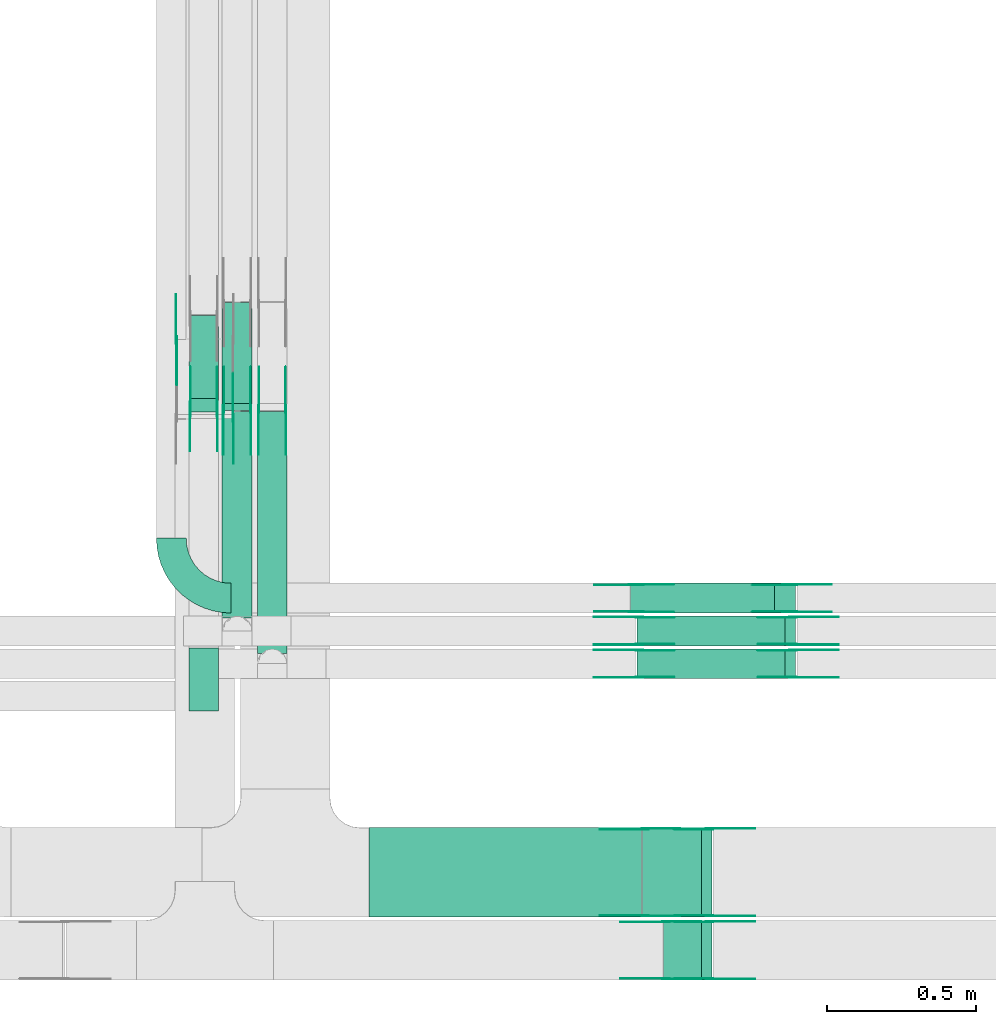
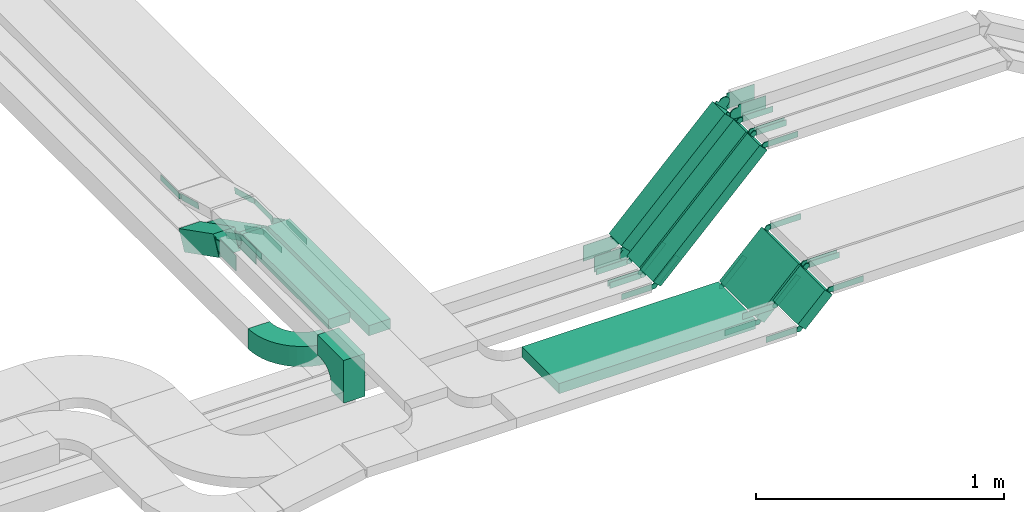
# One storey, part 15 of 19: 58 flow fittings, 10 flow segments.
"""IFC2X3 building model written with IfcOpenShell, lengths in millimetres."""

from ifc_helpers import new_model, entity, si_unit, converted_unit, derived_unit, direction, frame, frame_2d, origin, origin_2d_with_axis, place, context, subcontext, project, spatial, polyline, circle_curve, parameter, trimmed, segment, composite_curve, rectangle, outline, extrude, source, transform, mapped, material, type_object, type_shapes, element, save


model = new_model("IFC2X3")

# Units and contexts
model_context = context("Model", 3, precision=0.01, world=origin(), true_north=direction((6.12303176911189e-17, 1.0)))
body_context = subcontext(model_context, "Body", "Model", "MODEL_VIEW")
ifc_project = project(units=[si_unit("LENGTHUNIT", "METRE", prefix="MILLI"), si_unit("AREAUNIT", "SQUARE_METRE"), si_unit("VOLUMEUNIT", "CUBIC_METRE"), converted_unit("PLANEANGLEUNIT", "DEGREE", entity("IfcRatioMeasure", 0.0174532925199433), si_unit("PLANEANGLEUNIT", "RADIAN"), dimensions=[0, 0, 0, 0, 0, 0, 0]), si_unit("MASSUNIT", "GRAM", prefix="KILO"), derived_unit("MASSDENSITYUNIT", [(si_unit("MASSUNIT", "GRAM", prefix="KILO"), 1), (si_unit("LENGTHUNIT", "METRE"), -3)]), derived_unit("MOMENTOFINERTIAUNIT", [(si_unit("LENGTHUNIT", "METRE"), 4)]), si_unit("TIMEUNIT", "SECOND"), si_unit("FREQUENCYUNIT", "HERTZ"), si_unit("THERMODYNAMICTEMPERATUREUNIT", "DEGREE_CELSIUS"), derived_unit("THERMALTRANSMITTANCEUNIT", [(si_unit("MASSUNIT", "GRAM", prefix="KILO"), 1), (si_unit("THERMODYNAMICTEMPERATUREUNIT", "KELVIN"), -1), (si_unit("TIMEUNIT", "SECOND"), -3)]), derived_unit("VOLUMETRICFLOWRATEUNIT", [(si_unit("LENGTHUNIT", "METRE"), 3), (si_unit("TIMEUNIT", "SECOND"), -1)]), derived_unit("MASSFLOWRATEUNIT", [(si_unit("MASSUNIT", "GRAM", prefix="KILO"), 1), (si_unit("TIMEUNIT", "SECOND"), -1)]), derived_unit("ROTATIONALFREQUENCYUNIT", [(si_unit("TIMEUNIT", "SECOND"), -1)]), si_unit("ELECTRICCURRENTUNIT", "AMPERE"), si_unit("ELECTRICVOLTAGEUNIT", "VOLT"), si_unit("POWERUNIT", "WATT"), si_unit("FORCEUNIT", "NEWTON", prefix="KILO"), si_unit("ILLUMINANCEUNIT", "LUX"), si_unit("LUMINOUSFLUXUNIT", "LUMEN"), si_unit("LUMINOUSINTENSITYUNIT", "CANDELA"), derived_unit("USERDEFINED", [(si_unit("MASSUNIT", "GRAM", prefix="KILO"), -1), (si_unit("LENGTHUNIT", "METRE"), -2), (si_unit("TIMEUNIT", "SECOND"), 3), (si_unit("LUMINOUSFLUXUNIT", "LUMEN"), 1)]), derived_unit("LINEARVELOCITYUNIT", [(si_unit("LENGTHUNIT", "METRE"), 1), (si_unit("TIMEUNIT", "SECOND"), -1)]), si_unit("PRESSUREUNIT", "PASCAL"), derived_unit("USERDEFINED", [(si_unit("LENGTHUNIT", "METRE"), -2), (si_unit("MASSUNIT", "GRAM", prefix="KILO"), 1), (si_unit("TIMEUNIT", "SECOND"), -2)]), derived_unit("LINEARFORCEUNIT", [(si_unit("MASSUNIT", "GRAM", prefix="KILO"), 1), (si_unit("LENGTHUNIT", "METRE"), 1), (si_unit("TIMEUNIT", "SECOND"), -2), (si_unit("LENGTHUNIT", "METRE"), -1)]), derived_unit("PLANARFORCEUNIT", [(si_unit("MASSUNIT", "GRAM", prefix="KILO"), 1), (si_unit("LENGTHUNIT", "METRE"), 1), (si_unit("TIMEUNIT", "SECOND"), -2), (si_unit("LENGTHUNIT", "METRE"), -2)])], contexts=[model_context])

# Site, building, storey
site_placement = place(None, frame((0.0, -0.00077364408347762, 0.0)))
site = spatial("IfcSite", under=ifc_project, at=site_placement, CompositionType="ELEMENT")
building_placement = place(site_placement, origin())
building = spatial("IfcBuilding", under=site, at=building_placement, CompositionType="ELEMENT")
storey_placement = place(building_placement, frame((0.0, 0.0, 12000.0)))
storey = spatial("IfcBuildingStorey", under=building, at=storey_placement, CompositionType="ELEMENT", Elevation=12000.0)

# Flow segments
cable_carrier_segment_type = type_object("IfcCableCarrierSegmentType", PredefinedType="CABLETRAYSEGMENT")
flow_segment_1_placement = place(storey_placement, frame((60138.9654894683, 10518.8647764634, 2511.78931198406)))
element("IfcFlowSegment", 1, at=flow_segment_1_placement, inside=storey, type_object=cable_carrier_segment_type, context=body_context, shape_type="SweptSolid", body=[
    extrude(rectangle(XDim=99.9999999999996, YDim=313.488330030498, at=frame_2d((0.0, 0.0), x_axis=(0.0, 1.0))), frame((0.0, 162.359598644037, 115.710688015944), z_axis=(1.0, 0.0, 0.0), x_axis=(0.0, -0.891006524188386, 0.453990499739511)), (0.0, 0.0, 1.0), 100.000000000003),
])
flow_segment_2_placement = place(storey_placement, frame((60250.7778409658, 10524.8667454404, 2506.33963819353)))
element("IfcFlowSegment", 2, at=flow_segment_2_placement, inside=storey, type_object=cable_carrier_segment_type, context=body_context, shape_type="SweptSolid", body=[
    extrude(rectangle(XDim=50.0000000000023, YDim=380.5594995989, at=frame_2d((0.0, 0.0), x_axis=(0.0, 1.0))), frame((0.0, 180.890260985727, 108.660361806483), z_axis=(1.0, 0.0, 0.0), x_axis=(0.0, -0.891006524188355, 0.453990499739573)), (0.0, 0.0, 1.0), 99.9999999999946),
])
flow_segment_3_placement = place(storey_placement, frame((60250.7778409658, 9829.12206093069, 2680.0)))
element("IfcFlowSegment", 3, at=flow_segment_3_placement, inside=storey, type_object=cable_carrier_segment_type, context=body_context, shape_type="SweptSolid", body=[
    extrude(rectangle(XDim=692.037715986748, YDim=99.9999999999946, at=origin_2d_with_axis()), frame((50.0, 346.018857993374, 0.0), z_axis=(0.0, 0.0, 1.0), x_axis=(0.0, -1.0, 0.0)), (0.0, 0.0, 1.0), 50.0000000000016),
])
flow_segment_4_placement = place(storey_placement, frame((60368.3480842056, 9709.12206093071, 2680.0)))
element("IfcFlowSegment", 4, at=flow_segment_4_placement, inside=storey, type_object=cable_carrier_segment_type, context=body_context, shape_type="SweptSolid", body=[
    extrude(rectangle(XDim=812.037715986744, YDim=99.9999999999946, at=frame_2d((1.08002495835535e-12, 8.66506866259442e-12), x_axis=(1.0, 0.0))), frame((50.0, 406.018857993372, 0.0), z_axis=(0.0, 0.0, 1.0), x_axis=(0.0, -1.0, 0.0)), (0.0, 0.0, 1.0), 50.0000000000016),
])
flow_segment_5_placement = place(storey_placement, frame((61621.165755444, 9844.98776832002, 2531.16800153779)))
element("IfcFlowSegment", 5, at=flow_segment_5_placement, inside=storey, type_object=cable_carrier_segment_type, context=body_context, shape_type="SweptSolid", body=[
    extrude(rectangle(XDim=99.999999999999, YDim=99.9999999999989, at=frame_2d((0.0, 9.9582564416778e-12), x_axis=(0.0, 1.0))), frame((35.3553390593373, 50.0, 35.3553390593243), z_axis=(0.707106781186526, 0.0, 0.707106781186569), x_axis=(0.0, 1.0, 0.0)), (0.0, 0.0, 1.0), 681.584919885831),
])
for number, where in (
    (6, (61641.8764335627, 9734.98776832001, 2516.52334059716)),
    (7, (61641.8764335627, 9624.98776832001, 2516.52334059716)),
):
    element("IfcFlowSegment", number, at=place(storey_placement, frame(where)), inside=storey, type_object=cable_carrier_segment_type, context=body_context, shape_type="SweptSolid", body=[
        extrude(rectangle(XDim=49.9999999999895, YDim=99.9999999999989, at=frame_2d((0.0, 0.0), x_axis=(0.0, 1.0))), frame((17.67766952966, 50.0, 17.67766952966), z_axis=(0.707106781186548, 0.0, 0.707106781186548), x_axis=(0.0, 1.0, 0.0)), (0.0, 0.0, 1.0), 702.295598004474),
    ])
flow_segment_6_placement = place(storey_placement, frame((60742.5531425995, 8824.98776832001, 2800.0)))
element("IfcFlowSegment", 8, at=flow_segment_6_placement, inside=storey, type_object=cable_carrier_segment_type, context=body_context, shape_type="SweptSolid", body=[
    extrude(rectangle(XDim=914.543199050556, YDim=299.999999999999, at=frame_2d((-4.32009983342141e-12, 0.0), x_axis=(1.0, 0.0))), frame((457.271599525282, 150.0, 0.0)), (0.0, 0.0, 1.0), 50.0000000000016),
])
flow_segment_7_placement = place(storey_placement, frame((61661.631875556, 8824.98776832001, 2816.52334059709)))
element("IfcFlowSegment", 9, at=flow_segment_7_placement, inside=storey, type_object=cable_carrier_segment_type, context=body_context, shape_type="SweptSolid", body=[
    extrude(rectangle(XDim=278.03152929262, YDim=50.000000000011, at=frame_2d((7.67386154620908e-13, -7.65609797781508e-13), x_axis=(1.0, 0.0))), frame((115.976659402904, 0.0, 115.97665940291), z_axis=(0.0, 1.0, 0.0), x_axis=(0.70710678118652, 0.0, 0.707106781186575)), (0.0, 0.0, 1.0), 299.999999999999),
])
flow_segment_8_placement = place(storey_placement, frame((61731.6318755557, 8613.81713290522, 2886.52334059682)))
element("IfcFlowSegment", 10, at=flow_segment_8_placement, inside=storey, type_object=cable_carrier_segment_type, context=body_context, shape_type="SweptSolid", body=[
    extrude(rectangle(XDim=179.030212681478, YDim=50.0000000000033, at=frame_2d((-7.67386154620908e-13, 7.65609797781508e-13), x_axis=(1.0, 0.0))), frame((80.9744082418282, 0.0, 80.9744082418456), z_axis=(0.0, 1.0, 0.0), x_axis=(0.707106781186414, 0.0, 0.707106781186681)), (0.0, 0.0, 1.0), 200.0),
])

# Flow fittings
ifc_material_1 = material(Name="G")
cable_carrier_fitting_type_1 = type_object("IfcCableCarrierFittingType", PredefinedType="NOTDEFINED", material=ifc_material_1)
shared_shape_1 = source(origin(), body_context, "Body", "SweptSolid", [
    extrude(outline(composite_curve([segment(trimmed(circle_curve(frame_2d((-44.5901162790698, 0.0), x_axis=(1.0, 0.0)), 12.5), [parameter(90.0000000000007)], [parameter(270.0)], True, "PARAMETER"), True, "CONTINUOUS"), segment(polyline([(-44.5901162790697, -12.5), (-33.0901162790698, -12.5)]), True, "CONTINUOUS"), segment(polyline([(-33.0901162790698, -12.5), (-31.2296511627907, -14.5)]), True, "CONTINUOUS"), segment(polyline([(-31.2296511627907, -14.5), (108.90988372093, -14.5)]), True, "CONTINUOUS"), segment(polyline([(108.90988372093, -14.5), (108.90988372093, 14.5)]), True, "CONTINUOUS"), segment(polyline([(108.90988372093, 14.5), (-31.2296511627907, 14.5)]), True, "CONTINUOUS"), segment(polyline([(-31.2296511627907, 14.5), (-33.0901162790698, 12.5)]), True, "CONTINUOUS"), segment(polyline([(-33.0901162790698, 12.5), (-44.5901162790699, 12.5)]), True, "CONTINUOUS")], self_intersect=False)), frame((44.5901162790698, 0.0, 0.0), z_axis=(0.0, 0.0, -1.0), x_axis=(1.0, 0.0, 0.0)), (0.0, 0.0, -1.0), 2.0),
])
type_shapes(cable_carrier_fitting_type_1, [shared_shape_1])
for number, where, z_axis, x_axis in (
    (11, (60288.0131426097, 10499.7481729391, 2895.0), (1.0, 0.0, 0.0), (0.0, -1.0, 0.0)),
    (12, (61650.3530929656, 9830.44776833017, 2525.0), (0.0, 1.0, 0.0), (-1.0, 0.0, 0.0)),
    (13, (61650.3530929656, 9720.44776833017, 2525.0), (0.0, 1.0, 0.0), (-1.0, 0.0, 0.0)),
    (14, (61670.1085349589, 8829.52776830986, 2825.0), (0.0, -1.0, 0.0), (0.707106781186591, 0.0, 0.707106781186504)),
    (15, (61740.1085349586, 8618.35713289507, 2895.0), (0.0, -1.0, 0.0), (0.707106781186497, 0.0, 0.707106781186598)),
    (16, (62165.3530929656, 9830.44776833017, 3040.0), (0.0, 1.0, 0.0), (1.0, 0.0, 0.0)),
    (17, (61885.1085349589, 9120.44776833017, 3040.0), (0.0, 1.0, 0.0), (1.0, 0.0, 0.0)),
    (18, (61885.1040326364, 8809.27713291537, 3039.99549767765), (0.0, 1.0, 0.0), (1.0, 0.0, 0.0)),
    (19, (62165.3530929656, 9720.44776833017, 3040.0), (0.0, 1.0, 0.0), (1.0, 0.0, 0.0)),
    (20, (60463.8080842157, 10529.1220609307, 2705.0), (1.0, 0.0, 0.0), (0.0, -1.0, 0.0)),
    (21, (60346.2378409759, 10529.1220609307, 2705.0), (1.0, 0.0, 0.0), (0.0, -1.0, 0.0)),
):
    element("IfcFlowFitting", number, at=place(storey_placement, frame(where, z_axis=z_axis, x_axis=x_axis)), inside=storey, type_object=cable_carrier_fitting_type_1, material=ifc_material_1, context=body_context, shape_type="MappedRepresentation", body=[
        mapped(shared_shape_1, transform((0.0, 0.0, 0.0), scale=1.0)),
    ])
cable_carrier_fitting_type_2 = type_object("IfcCableCarrierFittingType", PredefinedType="NOTDEFINED", material=ifc_material_1)
shared_shape_2 = source(origin(), body_context, "Body", "SweptSolid", [
    extrude(outline(composite_curve([segment(trimmed(circle_curve(frame_2d((-44.5901162790697, 0.0), x_axis=(1.0, 0.0)), 12.5), [parameter(90.0000000000007)], [parameter(270.0)], True, "PARAMETER"), True, "CONTINUOUS"), segment(polyline([(-44.5901162790697, -12.5), (-33.0901162790697, -12.5)]), True, "CONTINUOUS"), segment(polyline([(-33.0901162790697, -12.5), (-31.2296511627907, -14.5)]), True, "CONTINUOUS"), segment(polyline([(-31.2296511627907, -14.5), (108.90988372093, -14.5)]), True, "CONTINUOUS"), segment(polyline([(108.90988372093, -14.5), (108.90988372093, 14.5)]), True, "CONTINUOUS"), segment(polyline([(108.90988372093, 14.5), (-31.2296511627907, 14.5)]), True, "CONTINUOUS"), segment(polyline([(-31.2296511627907, 14.5), (-33.0901162790698, 12.5)]), True, "CONTINUOUS"), segment(polyline([(-33.0901162790698, 12.5), (-44.5901162790699, 12.5)]), True, "CONTINUOUS")], self_intersect=False)), frame((44.5901162790697, 0.0, 0.0)), (0.0, 0.0, 1.0), 2.0),
])
type_shapes(cable_carrier_fitting_type_2, [shared_shape_2])
for number, where, z_axis, x_axis in (
    (22, (61650.3530929656, 9739.52776830985, 2525.0), (0.0, -1.0, 0.0), (-1.0, 0.0, 0.0)),
    (23, (61650.3530929656, 9629.52776830985, 2525.0), (0.0, -1.0, 0.0), (-1.0, 0.0, 0.0)),
    (24, (61670.1085349589, 9120.44776833018, 2825.0), (0.0, 1.0, 0.0), (0.707106781186591, 0.0, 0.707106781186504)),
    (25, (61740.1085349586, 8809.27713291539, 2895.0), (0.0, 1.0, 0.0), (0.707106781186497, 0.0, 0.707106781186598)),
    (26, (62165.3530929655, 9739.52776830985, 3040.0), (0.0, -1.0, 0.0), (1.0, 0.0, 0.0)),
    (27, (61885.1085349589, 8829.52776830985, 3040.0), (0.0, -1.0, 0.0), (1.0, 0.0, 0.0)),
    (28, (61885.1040326364, 8618.35713289506, 3039.99549767765), (0.0, -1.0, 0.0), (1.0, 0.0, 0.0)),
    (29, (60097.0931425894, 10760.9917294686, 2825.0), (-1.0, 0.0, 0.0), (0.0, 1.0, 0.0)),
    (30, (62165.3530929656, 9629.52776830985, 3040.0), (0.0, -1.0, 0.0), (1.0, 0.0, 0.0)),
    (31, (60372.8880841954, 10529.1220609307, 2705.0), (-1.0, 0.0, 0.0), (0.0, -1.0, 0.0)),
    (32, (60255.3178409556, 10529.1220609307, 2705.0), (-1.0, 0.0, 0.0), (0.0, -1.0, 0.0)),
):
    element("IfcFlowFitting", number, at=place(storey_placement, frame(where, z_axis=z_axis, x_axis=x_axis)), inside=storey, type_object=cable_carrier_fitting_type_2, material=ifc_material_1, context=body_context, shape_type="MappedRepresentation", body=[
        mapped(shared_shape_2, transform((0.0, 0.0, 0.0), scale=1.0)),
    ])
cable_carrier_fitting_type_3 = type_object("IfcCableCarrierFittingType", PredefinedType="NOTDEFINED", material=ifc_material_1)
shared_shape_3 = source(origin(), body_context, "Body", "SweptSolid", [
    extrude(outline(composite_curve([segment(trimmed(circle_curve(frame_2d((-44.5901162790698, 0.0), x_axis=(1.0, 0.0)), 12.5), [parameter(90.0000000000007)], [parameter(270.0)], True, "PARAMETER"), True, "CONTINUOUS"), segment(polyline([(-44.5901162790697, -12.5), (-33.0901162790698, -12.5)]), True, "CONTINUOUS"), segment(polyline([(-33.0901162790698, -12.5), (-31.2296511627907, -14.5)]), True, "CONTINUOUS"), segment(polyline([(-31.2296511627907, -14.5), (108.90988372093, -14.5)]), True, "CONTINUOUS"), segment(polyline([(108.90988372093, -14.5), (108.90988372093, 14.5)]), True, "CONTINUOUS"), segment(polyline([(108.90988372093, 14.5), (-31.2296511627907, 14.5)]), True, "CONTINUOUS"), segment(polyline([(-31.2296511627907, 14.5), (-33.0901162790698, 12.5)]), True, "CONTINUOUS"), segment(polyline([(-33.0901162790698, 12.5), (-44.5901162790699, 12.5)]), True, "CONTINUOUS")], self_intersect=False)), frame((44.5901162790698, 0.0, 0.0), z_axis=(0.0, 0.0, -1.0), x_axis=(1.0, 0.0, 0.0)), (0.0, 0.0, -1.0), 2.0),
])
type_shapes(cable_carrier_fitting_type_3, [shared_shape_3])
for number, where, z_axis, x_axis in (
    (33, (61650.3530929656, 9741.52776830985, 2525.0), (0.0, -1.0, 0.0), (0.707106781186565, 0.0, 0.70710678118653)),
    (34, (61650.3530929656, 9631.52776830986, 2525.0), (0.0, -1.0, 0.0), (0.70710678118656, 0.0, 0.707106781186535)),
    (35, (61670.1085349589, 9118.44776833018, 2825.0), (0.0, 1.0, 0.0), (-1.0, 0.0, 0.0)),
    (36, (61740.1085349586, 8807.27713291538, 2895.0), (0.0, 1.0, 0.0), (-1.0, 0.0, 0.0)),
    (37, (62165.3530929656, 9741.52776830985, 3040.0), (0.0, -1.0, 0.0), (-0.70710678118656, 0.0, -0.707106781186535)),
    (38, (61885.1085349589, 8831.52776830985, 3040.0), (0.0, -1.0, 0.0), (-0.707106781186608, 0.0, -0.707106781186487)),
    (39, (61885.1040326364, 8620.35713289506, 3039.99549767765), (0.0, -1.0, 0.0), (-0.707106781186586, 0.0, -0.707106781186509)),
    (40, (60099.0931425894, 10760.9917294686, 2825.0), (-1.0, 0.0, 0.0), (0.0, -0.965925826289068, 0.258819045102522)),
    (41, (62165.3530929656, 9631.52776830986, 3040.0), (0.0, -1.0, 0.0), (-0.70710678118656, 0.0, -0.707106781186535)),
    (42, (60374.8880841954, 10529.1220609307, 2705.0), (-1.0, 0.0, 0.0), (0.0, 0.891006524188382, -0.453990499739519)),
    (43, (60257.3178409556, 10529.1220609307, 2705.0), (-1.0, 0.0, 0.0), (0.0, 0.891006524188381, -0.453990499739522)),
):
    element("IfcFlowFitting", number, at=place(storey_placement, frame(where, z_axis=z_axis, x_axis=x_axis)), inside=storey, type_object=cable_carrier_fitting_type_3, material=ifc_material_1, context=body_context, shape_type="MappedRepresentation", body=[
        mapped(shared_shape_3, transform((0.0, 0.0, 0.0), scale=1.0)),
    ])
cable_carrier_fitting_type_4 = type_object("IfcCableCarrierFittingType", PredefinedType="NOTDEFINED", material=ifc_material_1)
shared_shape_4 = source(origin(), body_context, "Body", "SweptSolid", [
    extrude(outline(composite_curve([segment(trimmed(circle_curve(frame_2d((-44.5901162790697, 0.0), x_axis=(1.0, 0.0)), 12.5), [parameter(90.0000000000007)], [parameter(270.0)], True, "PARAMETER"), True, "CONTINUOUS"), segment(polyline([(-44.5901162790697, -12.5), (-33.0901162790697, -12.5)]), True, "CONTINUOUS"), segment(polyline([(-33.0901162790697, -12.5), (-31.2296511627907, -14.5)]), True, "CONTINUOUS"), segment(polyline([(-31.2296511627907, -14.5), (108.90988372093, -14.5)]), True, "CONTINUOUS"), segment(polyline([(108.90988372093, -14.5), (108.90988372093, 14.5)]), True, "CONTINUOUS"), segment(polyline([(108.90988372093, 14.5), (-31.2296511627907, 14.5)]), True, "CONTINUOUS"), segment(polyline([(-31.2296511627907, 14.5), (-33.0901162790698, 12.5)]), True, "CONTINUOUS"), segment(polyline([(-33.0901162790698, 12.5), (-44.5901162790699, 12.5)]), True, "CONTINUOUS")], self_intersect=False)), frame((44.5901162790697, 0.0, 0.0)), (0.0, 0.0, 1.0), 2.0),
])
type_shapes(cable_carrier_fitting_type_4, [shared_shape_4])
for number, where, z_axis, x_axis in (
    (44, (60286.0131426097, 10499.7481729391, 2895.0), (1.0, 0.0, 0.0), (0.0, 0.965925826289068, -0.258819045102521)),
    (45, (61650.3530929656, 9828.44776833017, 2525.0), (0.0, 1.0, 0.0), (0.707106781186565, 0.0, 0.70710678118653)),
    (46, (61650.3530929656, 9718.44776833017, 2525.0), (0.0, 1.0, 0.0), (0.70710678118656, 0.0, 0.707106781186535)),
    (47, (61670.1085349589, 8831.52776830986, 2825.0), (0.0, -1.0, 0.0), (-1.0, 0.0, 0.0)),
    (48, (61740.1085349586, 8620.35713289507, 2895.0), (0.0, -1.0, 0.0), (-1.0, 0.0, 0.0)),
    (49, (62165.3530929656, 9828.44776833017, 3040.0), (0.0, 1.0, 0.0), (-0.70710678118656, 0.0, -0.707106781186535)),
    (50, (61885.1085349589, 9118.44776833016, 3040.0), (0.0, 1.0, 0.0), (-0.707106781186608, 0.0, -0.707106781186487)),
    (51, (61885.1040326364, 8807.27713291537, 3039.99549767765), (0.0, 1.0, 0.0), (-0.707106781186586, 0.0, -0.707106781186509)),
    (52, (62165.3530929656, 9718.44776833017, 3040.0), (0.0, 1.0, 0.0), (-0.70710678118656, 0.0, -0.707106781186535)),
    (53, (60461.8080842157, 10529.1220609307, 2705.0), (1.0, 0.0, 0.0), (0.0, 0.891006524188382, -0.453990499739519)),
    (54, (60344.2378409759, 10529.1220609307, 2705.0), (1.0, 0.0, 0.0), (0.0, 0.891006524188381, -0.453990499739522)),
):
    element("IfcFlowFitting", number, at=place(storey_placement, frame(where, z_axis=z_axis, x_axis=x_axis)), inside=storey, type_object=cable_carrier_fitting_type_4, material=ifc_material_1, context=body_context, shape_type="MappedRepresentation", body=[
        mapped(shared_shape_4, transform((0.0, 0.0, 0.0), scale=1.0)),
    ])
cable_carrier_fitting_type_5 = type_object("IfcCableCarrierFittingType", PredefinedType="NOTDEFINED", material=ifc_material_1)
shared_shape_5 = source(origin(), body_context, "Body", "SweptSolid", [
    extrude(outline(composite_curve([segment(trimmed(circle_curve(frame_2d((-41.4651162790697, 0.0), x_axis=(1.0, 0.0)), 25.0), [parameter(90.0000000000007)], [parameter(270.0)], True, "PARAMETER"), True, "CONTINUOUS"), segment(polyline([(-41.4651162790697, -25.0), (-29.9651162790697, -25.0)]), True, "CONTINUOUS"), segment(polyline([(-29.9651162790697, -25.0), (-28.1046511627907, -38.5)]), True, "CONTINUOUS"), segment(polyline([(-28.1046511627907, -38.5), (99.5348837209303, -38.5)]), True, "CONTINUOUS"), segment(polyline([(99.5348837209303, -38.5), (99.5348837209303, 38.5)]), True, "CONTINUOUS"), segment(polyline([(99.5348837209303, 38.5), (-28.1046511627907, 38.5)]), True, "CONTINUOUS"), segment(polyline([(-28.1046511627907, 38.5), (-29.9651162790697, 25.0)]), True, "CONTINUOUS"), segment(polyline([(-29.9651162790697, 25.0), (-41.46511627907, 25.0)]), True, "CONTINUOUS")], self_intersect=False)), frame((41.4651162790697, 0.0, 0.0), z_axis=(0.0, 0.0, -1.0), x_axis=(1.0, 0.0, 0.0)), (0.0, 0.0, -1.0), 2.0),
])
type_shapes(cable_carrier_fitting_type_5, [shared_shape_5])
for number, where, z_axis, x_axis in (
    (55, (60234.4254894785, 10529.1220609307, 2705.0), (1.0, 0.0, 0.0), (0.0, -1.0, 0.0)),
    (56, (61639.9977539062, 9849.52776830987, 2550.0), (0.0, -1.0, 0.0), (0.707106781186429, 0.0, 0.707106781186666)),
    (57, (62154.9977539062, 9940.44776833018, 3065.0), (0.0, 1.0, 0.0), (1.0, 0.0, 0.0)),
):
    element("IfcFlowFitting", number, at=place(storey_placement, frame(where, z_axis=z_axis, x_axis=x_axis)), inside=storey, type_object=cable_carrier_fitting_type_5, material=ifc_material_1, context=body_context, shape_type="MappedRepresentation", body=[
        mapped(shared_shape_5, transform((0.0, 0.0, 0.0), scale=1.0)),
    ])
cable_carrier_fitting_type_6 = type_object("IfcCableCarrierFittingType", PredefinedType="NOTDEFINED", material=ifc_material_1)
shared_shape_6 = source(origin(), body_context, "Body", "SweptSolid", [
    extrude(outline(composite_curve([segment(trimmed(circle_curve(frame_2d((-41.4651162790697, 0.0), x_axis=(1.0, 0.0)), 25.0), [parameter(90.0000000000007)], [parameter(270.0)], True, "PARAMETER"), True, "CONTINUOUS"), segment(polyline([(-41.4651162790697, -25.0), (-29.9651162790697, -25.0)]), True, "CONTINUOUS"), segment(polyline([(-29.9651162790697, -25.0), (-28.1046511627907, -38.5)]), True, "CONTINUOUS"), segment(polyline([(-28.1046511627907, -38.5), (99.5348837209303, -38.5)]), True, "CONTINUOUS"), segment(polyline([(99.5348837209303, -38.5), (99.5348837209303, 38.5)]), True, "CONTINUOUS"), segment(polyline([(99.5348837209303, 38.5), (-28.1046511627907, 38.5)]), True, "CONTINUOUS"), segment(polyline([(-28.1046511627907, 38.5), (-29.9651162790697, 25.0)]), True, "CONTINUOUS"), segment(polyline([(-29.9651162790697, 25.0), (-41.46511627907, 25.0)]), True, "CONTINUOUS")], self_intersect=False)), frame((41.4651162790697, 0.0, 0.0)), (0.0, 0.0, 1.0), 2.0),
])
type_shapes(cable_carrier_fitting_type_6, [shared_shape_6])
for number, where, z_axis, x_axis in (
    (58, (60143.5054894581, 10529.1220609307, 2705.0), (-1.0, 0.0, 0.0), (0.0, -1.0, 0.0)),
    (59, (61639.9977539062, 9940.44776833019, 2550.0), (0.0, 1.0, 0.0), (0.707106781186429, 0.0, 0.707106781186666)),
    (60, (62154.9977539062, 9849.52776830986, 3065.0), (0.0, -1.0, 0.0), (1.0, 0.0, 0.0)),
):
    element("IfcFlowFitting", number, at=place(storey_placement, frame(where, z_axis=z_axis, x_axis=x_axis)), inside=storey, type_object=cable_carrier_fitting_type_6, material=ifc_material_1, context=body_context, shape_type="MappedRepresentation", body=[
        mapped(shared_shape_6, transform((0.0, 0.0, 0.0), scale=1.0)),
    ])
cable_carrier_fitting_type_7 = type_object("IfcCableCarrierFittingType", PredefinedType="NOTDEFINED", material=ifc_material_1)
shared_shape_7 = source(origin(), body_context, "Body", "SweptSolid", [
    extrude(outline(composite_curve([segment(trimmed(circle_curve(frame_2d((-41.4651162790697, 0.0), x_axis=(1.0, 0.0)), 25.0), [parameter(90.0000000000007)], [parameter(270.0)], True, "PARAMETER"), True, "CONTINUOUS"), segment(polyline([(-41.4651162790697, -25.0), (-29.9651162790697, -25.0)]), True, "CONTINUOUS"), segment(polyline([(-29.9651162790697, -25.0), (-28.1046511627907, -38.5)]), True, "CONTINUOUS"), segment(polyline([(-28.1046511627907, -38.5), (99.5348837209303, -38.5)]), True, "CONTINUOUS"), segment(polyline([(99.5348837209303, -38.5), (99.5348837209303, 38.5)]), True, "CONTINUOUS"), segment(polyline([(99.5348837209303, 38.5), (-28.1046511627907, 38.5)]), True, "CONTINUOUS"), segment(polyline([(-28.1046511627907, 38.5), (-29.9651162790697, 25.0)]), True, "CONTINUOUS"), segment(polyline([(-29.9651162790697, 25.0), (-41.46511627907, 25.0)]), True, "CONTINUOUS")], self_intersect=False)), frame((41.4651162790697, 0.0, 0.0), z_axis=(0.0, 0.0, -1.0), x_axis=(1.0, 0.0, 0.0)), (0.0, 0.0, -1.0), 2.0),
])
type_shapes(cable_carrier_fitting_type_7, [shared_shape_7])
for number, where, z_axis, x_axis in (
    (61, (60145.5054894581, 10529.1220609307, 2705.0), (-1.0, 0.0, 0.0), (0.0, 0.891006524188381, -0.453990499739522)),
    (62, (61639.9977539062, 9938.44776833019, 2550.0), (0.0, 1.0, 0.0), (-1.0, 0.0, 0.0)),
    (63, (62154.9977539062, 9851.52776830986, 3065.0), (0.0, -1.0, 0.0), (-0.70710678118654, 0.0, -0.707106781186555)),
):
    element("IfcFlowFitting", number, at=place(storey_placement, frame(where, z_axis=z_axis, x_axis=x_axis)), inside=storey, type_object=cable_carrier_fitting_type_7, material=ifc_material_1, context=body_context, shape_type="MappedRepresentation", body=[
        mapped(shared_shape_7, transform((0.0, 0.0, 0.0), scale=1.0)),
    ])
cable_carrier_fitting_type_8 = type_object("IfcCableCarrierFittingType", PredefinedType="NOTDEFINED", material=ifc_material_1)
shared_shape_8 = source(origin(), body_context, "Body", "SweptSolid", [
    extrude(outline(composite_curve([segment(trimmed(circle_curve(frame_2d((-41.4651162790697, 0.0), x_axis=(1.0, 0.0)), 25.0), [parameter(90.0000000000007)], [parameter(270.0)], True, "PARAMETER"), True, "CONTINUOUS"), segment(polyline([(-41.4651162790697, -25.0), (-29.9651162790697, -25.0)]), True, "CONTINUOUS"), segment(polyline([(-29.9651162790697, -25.0), (-28.1046511627907, -38.5)]), True, "CONTINUOUS"), segment(polyline([(-28.1046511627907, -38.5), (99.5348837209303, -38.5)]), True, "CONTINUOUS"), segment(polyline([(99.5348837209303, -38.5), (99.5348837209303, 38.5)]), True, "CONTINUOUS"), segment(polyline([(99.5348837209303, 38.5), (-28.1046511627907, 38.5)]), True, "CONTINUOUS"), segment(polyline([(-28.1046511627907, 38.5), (-29.9651162790697, 25.0)]), True, "CONTINUOUS"), segment(polyline([(-29.9651162790697, 25.0), (-41.46511627907, 25.0)]), True, "CONTINUOUS")], self_intersect=False)), frame((41.4651162790697, 0.0, 0.0)), (0.0, 0.0, 1.0), 2.0),
])
type_shapes(cable_carrier_fitting_type_8, [shared_shape_8])
for number, where, z_axis, x_axis in (
    (64, (60232.4254894785, 10529.1220609307, 2705.0), (1.0, 0.0, 0.0), (0.0, 0.891006524188381, -0.453990499739522)),
    (65, (61639.9977539062, 9851.52776830988, 2550.0), (0.0, -1.0, 0.0), (-1.0, 0.0, 0.0)),
    (66, (62154.9977539062, 9938.44776833018, 3065.0), (0.0, 1.0, 0.0), (-0.70710678118654, 0.0, -0.707106781186555)),
):
    element("IfcFlowFitting", number, at=place(storey_placement, frame(where, z_axis=z_axis, x_axis=x_axis)), inside=storey, type_object=cable_carrier_fitting_type_8, material=ifc_material_1, context=body_context, shape_type="MappedRepresentation", body=[
        mapped(shared_shape_8, transform((0.0, 0.0, 0.0), scale=1.0)),
    ])
ifc_material_2 = material()
cable_carrier_fitting_type_9 = type_object("IfcCableCarrierFittingType", Name="470_DKC_S5_Variable Angle Elbow 0-45:-", PredefinedType="NOTDEFINED", material=ifc_material_2)
shared_shape_9 = source(origin(), body_context, "Body", "SweptSolid", [
    extrude(outline(composite_curve([segment(polyline([(-100.749999999999, -150.250000000001), (-99.7499999999981, -150.250000000001)]), True, "CONTINUOUS"), segment(trimmed(circle_curve(frame_2d((-99.7500000000006, 99.7499999999987), x_axis=(0.0, -1.0)), 250.0), [parameter(0.0)], [parameter(90.0000000000001)], True, "PARAMETER"), True, "CONTINUOUS"), segment(polyline([(150.249999999999, 99.7500000000013), (150.249999999999, 100.750000000001)]), True, "CONTINUOUS"), segment(polyline([(150.249999999999, 100.750000000001), (50.2499999999992, 100.750000000001)]), True, "CONTINUOUS"), segment(polyline([(50.2499999999992, 100.750000000001), (50.2499999999992, 99.7500000000002)]), True, "CONTINUOUS"), segment(trimmed(circle_curve(frame_2d((-99.7500000000006, 99.7499999999987), x_axis=(0.0, -1.0)), 150.0), [parameter(0.0)], [parameter(90.0000000000001)], True, "PARAMETER"), False, "CONTINUOUS"), segment(polyline([(-99.7499999999989, -50.2500000000011), (-100.75, -50.2500000000011)]), True, "CONTINUOUS"), segment(polyline([(-100.75, -50.2500000000011), (-100.749999999999, -150.250000000001)]), True, "CONTINUOUS")], self_intersect=False)), frame((-100.249999999991, 100.249999999992, -50.0)), (0.0, 0.0, 1.0), 100.0),
])
type_shapes(cable_carrier_fitting_type_9, [shared_shape_9])
flow_fitting_1_placement = place(storey_placement, frame((60079.9977539062, 9894.98776832, 2550.0), z_axis=(0.0, 0.0, 1.0), x_axis=(0.0, -1.0, 0.0)))
element("IfcFlowFitting", 67, at=flow_fitting_1_placement, inside=storey, type_object=cable_carrier_fitting_type_9, material=ifc_material_2, Name="470_DKC_S5_Variable Angle Elbow 0-45:-", ObjectType="470_DKC_S5_Variable Angle Elbow 0-45:-", context=body_context, shape_type="MappedRepresentation", body=[
    mapped(shared_shape_9, transform((0.0, 0.0, 0.0), scale=1.0)),
])
cable_carrier_fitting_type_10 = type_object("IfcCableCarrierFittingType", Name="470_DKC_S5_CDV 90 external vertical angle:-", PredefinedType="NOTDEFINED", material=ifc_material_2)
shared_shape_10 = source(origin(), body_context, "Body", "SweptSolid", [
    extrude(outline(composite_curve([segment(polyline([(65.7142857142854, 14.2857142857149), (95.7142857142855, 14.2857142857149)]), True, "CONTINUOUS"), segment(polyline([(95.7142857142855, 14.2857142857149), (95.7142857142855, 114.285714285713)]), True, "CONTINUOUS"), segment(polyline([(95.7142857142855, 114.285714285713), (-114.285714285714, 114.285714285713)]), True, "CONTINUOUS"), segment(polyline([(-114.285714285714, 114.285714285713), (-114.285714285714, -95.7142857142853)]), True, "CONTINUOUS"), segment(polyline([(-114.285714285714, -95.7142857142853), (-14.2857142857144, -95.7142857142853)]), True, "CONTINUOUS"), segment(polyline([(-14.2857142857145, -95.7142857142853), (-14.2857142857145, -65.7142857142849)]), True, "CONTINUOUS"), segment(trimmed(circle_curve(frame_2d((65.7142857142855, -65.714285714285), x_axis=(-1.0, 0.0)), 80.0), [parameter(270.0)], [parameter(2.54444374517082e-13)], True, "PARAMETER"), False, "CONTINUOUS")], self_intersect=False)), frame((-64.2857142857073, 64.2857142857068, -49.0), z_axis=(0.0, 0.0, 1.0), x_axis=(-1.0, 0.0, 0.0)), (0.0, 0.0, 1.0), 99.0000000000002),
])
type_shapes(cable_carrier_fitting_type_10, [shared_shape_10])
flow_fitting_2_placement = place(storey_placement, frame((60188.9654894683, 9567.12992335929, 2705.0), z_axis=(1.0, 0.0, 0.0), x_axis=(0.0, -1.0, 0.0)))
element("IfcFlowFitting", 68, at=flow_fitting_2_placement, inside=storey, type_object=cable_carrier_fitting_type_10, material=ifc_material_2, Name="470_DKC_S5_90 external vertical angle", ObjectType="470_DKC_S5_CDV 90 external vertical angle:-", context=body_context, shape_type="MappedRepresentation", body=[
    mapped(shared_shape_10, transform((0.0, 0.0, 0.0), scale=1.0)),
])

save(model, "model.ifc")
